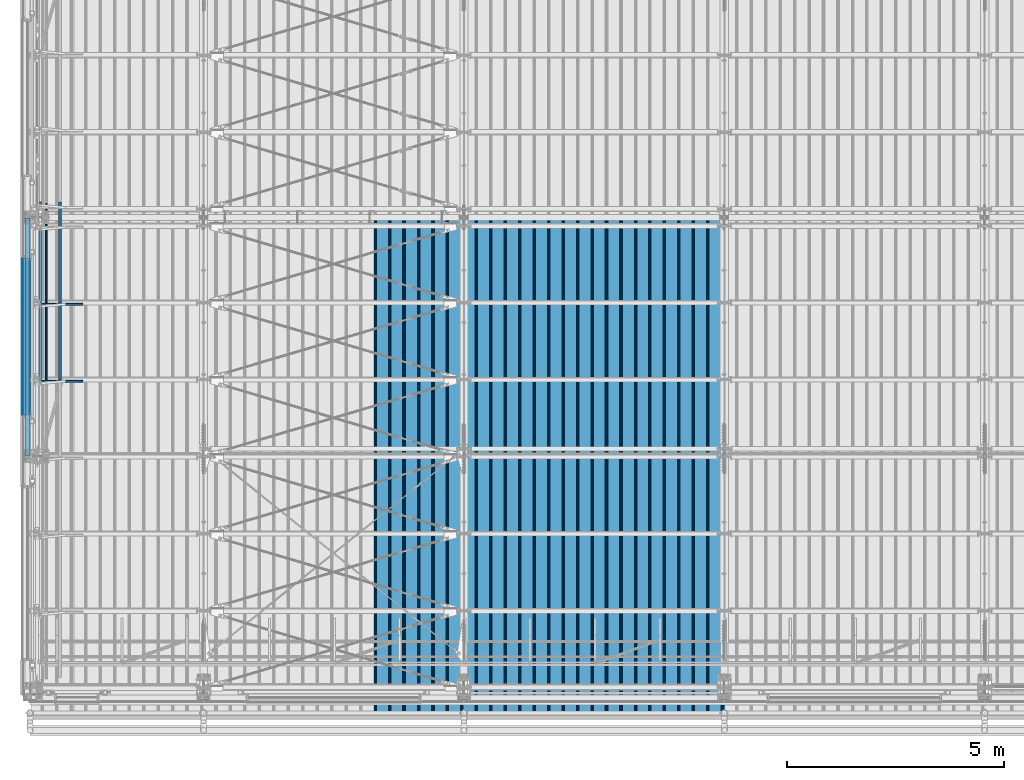
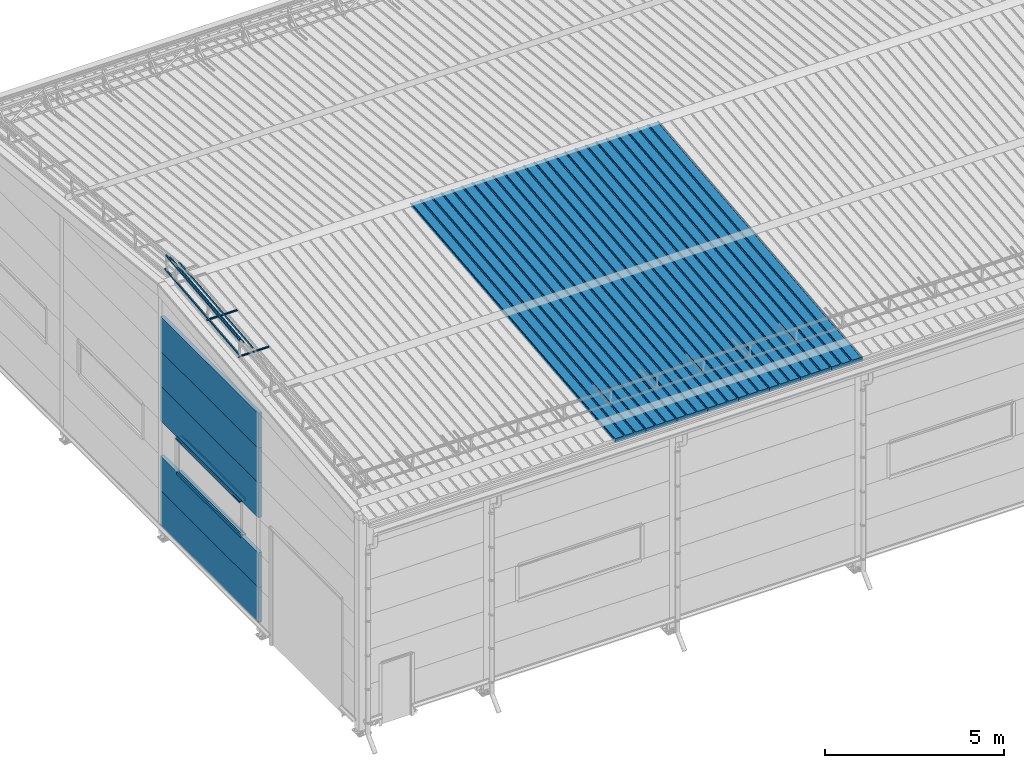
# One storey, part 38 of 709: 30 beams, 30 elements without a shape of their own.
"""IFC4 building model written with IfcOpenShell, lengths in millimetres."""

import ifcopenshell
import ifcopenshell.guid

model = None  # the IFC model being written
_history = None  # IfcOwnerHistory: only IFC2X3 demands one
_inside = {}  # id of a spatial element -> (the spatial element, [elements in it])
_under = {}  # id of a project, library or spatial element -> (it, [spatial elements below it])
_declared = {}  # id of a project -> (the project, [libraries it declares])
_typed = {}  # id of a type object -> (the type object, [elements of that type])
_made_of = {}  # id of a material, layer set ... -> (it, [elements and type objects made of it])


def new_model(schema):
    """Start an empty IFC model of exactly this schema.

    Asked for "IFC4X3", IfcOpenShell would pick the latest addendum, in which some entities
    have other attributes; the version numbers below select the first issue.
    IFC2X3 requires an IfcOwnerHistory on every rooted entity: one is made here for all.
    """
    global model, _history
    if schema == "IFC4X3":
        model = ifcopenshell.file(schema_version=(4, 3, 0, 0))
    else:
        model = ifcopenshell.file(schema=schema)
    _inside.clear()
    _under.clear()
    _declared.clear()
    _typed.clear()
    _made_of.clear()
    _history = None
    if model.schema == "IFC2X3":
        org = make("IfcOrganization", Name="unknown")
        user = make(
            "IfcPersonAndOrganization",
            ThePerson=make("IfcPerson", FamilyName="unknown"),
            TheOrganization=org,
        )
        app = make(
            "IfcApplication",
            ApplicationDeveloper=org,
            Version="unknown",
            ApplicationFullName="unknown",
            ApplicationIdentifier="unknown",
        )
        _history = make(
            "IfcOwnerHistory",
            OwningUser=user,
            OwningApplication=app,
            ChangeAction="ADDED",
            CreationDate=0,
        )
    return model


def make(cls, **values):
    """One entity of the class cls with the attributes given. An attribute that is None is left unset."""
    return model.create_entity(
        cls, **{name: value for name, value in values.items() if value is not None}
    )


def rooted(cls, **values):
    """An entity with a GlobalId (a new one), such as an element, a storey or a relation."""
    return make(cls, GlobalId=ifcopenshell.guid.new(), OwnerHistory=_history, **values)


def si_unit(unit_type, name, prefix=None):
    """IfcSIUnit, for example si_unit("LENGTHUNIT", "METRE", prefix="MILLI")."""
    return make("IfcSIUnit", UnitType=unit_type, Prefix=prefix, Name=name)


def assignment(units):
    """IfcUnitAssignment: the units of a project."""
    return None if units is None else make("IfcUnitAssignment", Units=units)


def point(xyz):
    """IfcCartesianPoint."""
    return None if xyz is None else make("IfcCartesianPoint", Coordinates=xyz)


def direction(xyz):
    """IfcDirection."""
    return None if xyz is None else make("IfcDirection", DirectionRatios=xyz)


def frame(location, z_axis=None, x_axis=None):
    """IfcAxis2Placement3D, a coordinate frame: its origin and axes. An axis left out is left unset."""
    return make(
        "IfcAxis2Placement3D",
        Location=point(location),
        Axis=direction(z_axis),
        RefDirection=direction(x_axis),
    )


def origin_with_axes():
    """The frame at (0, 0, 0) with the z axis (0, 0, 1) and the x axis (1, 0, 0) written out."""
    return frame((0.0, 0.0, 0.0), z_axis=(0.0, 0.0, 1.0), x_axis=(1.0, 0.0, 0.0))


def place(relative_to, where):
    """IfcLocalPlacement: puts the frame where relative to a parent placement (None: the world)."""
    return make(
        "IfcLocalPlacement", PlacementRelTo=relative_to, RelativePlacement=where
    )


def context(
    kind, dimensions, precision=None, world=None, true_north=None, identifier=None
):
    """IfcGeometricRepresentationContext, for example the 3D "Model" context."""
    return make(
        "IfcGeometricRepresentationContext",
        ContextIdentifier=identifier,
        ContextType=kind,
        CoordinateSpaceDimension=dimensions,
        Precision=precision,
        WorldCoordinateSystem=world,
        TrueNorth=true_north,
    )


def subcontext(parent, identifier, kind, view, scale=None):
    """IfcGeometricRepresentationSubContext, for example "Body" below "Model"."""
    return make(
        "IfcGeometricRepresentationSubContext",
        ContextIdentifier=identifier,
        ContextType=kind,
        ParentContext=parent,
        TargetScale=scale,
        TargetView=view,
    )


def project(units=None, contexts=None):
    """IfcProject with its units and contexts."""
    return rooted(
        "IfcProject",
        Name="project",
        RepresentationContexts=contexts,
        UnitsInContext=assignment(units),
    )


def spatial(cls, under=None, at=None, **own):
    """A site, building, storey or space (cls), placed at a placement, below another one or the project."""
    s = rooted(cls, ObjectPlacement=at, **own)
    if under is not None:
        _under.setdefault(under.id(), (under, []))[1].append(s)
    return s


def point_list(points):
    """IfcCartesianPointList2D or 3D."""
    cls = (
        "IfcCartesianPointList2D" if len(points[0]) == 2 else "IfcCartesianPointList3D"
    )
    return make(cls, CoordList=points)


def line(*indices):
    """IfcLineIndex: a straight run through numbered points of an indexed curve."""
    return model.create_entity("IfcLineIndex", indices)


def indexed_curve(points, segments=None, self_intersect=None):
    """IfcIndexedPolyCurve: lines and arcs through numbered points (the first is 1)."""
    return make(
        "IfcIndexedPolyCurve",
        Points=point_list(points),
        Segments=segments,
        SelfIntersect=self_intersect,
    )


def outline(outer, holes=None, kind="AREA"):
    """IfcArbitraryClosedProfileDef: a profile drawn as a closed curve; with holes, ...WithVoids."""
    if holes is None:
        return make("IfcArbitraryClosedProfileDef", ProfileType=kind, OuterCurve=outer)
    return make(
        "IfcArbitraryProfileDefWithVoids",
        ProfileType=kind,
        OuterCurve=outer,
        InnerCurves=holes,
    )


def extrude(swept, where, along, depth):
    """IfcExtrudedAreaSolid: the profile swept, set in the frame where, extruded along a direction by depth."""
    return make(
        "IfcExtrudedAreaSolid",
        SweptArea=swept,
        Position=where,
        ExtrudedDirection=direction(along),
        Depth=depth,
    )


def shape(context_of_items, identifier, shape_type, items):
    """IfcShapeRepresentation: the items that make up one representation, for example the "Body"."""
    return make(
        "IfcShapeRepresentation",
        ContextOfItems=context_of_items,
        RepresentationIdentifier=identifier,
        RepresentationType=shape_type,
        Items=items,
    )


def material(Name=None, Category=None):
    """IfcMaterial."""
    return make("IfcMaterial", Name=Name, Category=Category)


def made_of(thing, what):
    """Note that an element or type object is made of a material, layer set ...; save() writes the relation."""
    if what is not None:
        _made_of.setdefault(what.id(), (what, []))[1].append(thing)
    return thing


def element(
    cls,
    number,
    at=None,
    inside=None,
    cuts=None,
    type_object=None,
    material=None,
    context=None,
    identifier="Body",
    shape_type=None,
    held_by="IfcProductDefinitionShape",
    body=None,
    shapes=None,
    **own,
):
    """One element of the class cls, such as IfcWall. Its Tag is "e" and its number.

    at: its placement. inside: the storey or other place that contains it. cuts: it is an
    opening in that element (IfcRelVoidsElement). A single representation is given by context,
    identifier, shape_type and body (its items); several are given by shapes. held_by: the class
    of the entity that holds the representations. save() writes the other relations.
    """
    e = rooted(cls, Tag="e%d" % number, ObjectPlacement=at, **own)
    if body is not None:
        shapes = [shape(context, identifier, shape_type, body)]
    if shapes is not None:
        e.Representation = make(held_by, Representations=shapes)
    if inside is not None:
        _inside.setdefault(inside.id(), (inside, []))[1].append(e)
    if cuts is not None:
        rooted(
            "IfcRelVoidsElement", RelatingBuildingElement=cuts, RelatedOpeningElement=e
        )
    if type_object is not None:
        _typed.setdefault(type_object.id(), (type_object, []))[1].append(e)
    return made_of(e, material)


def aggregate(whole, parts):
    """IfcRelAggregates: a whole, such as a stair, and the parts it consists of."""
    return rooted("IfcRelAggregates", RelatingObject=whole, RelatedObjects=parts)


def save(model, path):
    """Write the relations noted so far, then the file.

    IfcRelAggregates (storeys below a building ...), IfcRelContainedInSpatialStructure (elements
    in a storey), IfcRelDefinesByType, IfcRelAssociatesMaterial and IfcRelDeclares: one each for
    every whole, place, type object, material and project.
    """
    for whole, parts in _under.values():
        aggregate(whole, parts)
    for where, things in _inside.values():
        rooted(
            "IfcRelContainedInSpatialStructure",
            RelatedElements=things,
            RelatingStructure=where,
        )
    for kind, things in _typed.values():
        rooted("IfcRelDefinesByType", RelatedObjects=things, RelatingType=kind)
    for what, things in _made_of.values():
        rooted("IfcRelAssociatesMaterial", RelatedObjects=things, RelatingMaterial=what)
    for by, libraries in _declared.values():
        rooted("IfcRelDeclares", RelatingContext=by, RelatedDefinitions=libraries)
    model.write(path)


model = new_model("IFC4")

# Units and contexts
model_context = context("Model", 3, precision=0.2, world=origin_with_axes(), true_north=direction((0.0, 1.0)))
body_context = subcontext(model_context, "Body", "Model", "MODEL_VIEW")
ifc_project = project(units=[si_unit("LENGTHUNIT", "METRE", prefix="MILLI"), si_unit("AREAUNIT", "SQUARE_METRE"), si_unit("VOLUMEUNIT", "CUBIC_METRE"), si_unit("MASSUNIT", "GRAM", prefix="KILO"), si_unit("TIMEUNIT", "SECOND"), si_unit("PLANEANGLEUNIT", "RADIAN"), si_unit("SOLIDANGLEUNIT", "STERADIAN"), si_unit("THERMODYNAMICTEMPERATUREUNIT", "DEGREE_CELSIUS"), si_unit("LUMINOUSINTENSITYUNIT", "LUMEN")], contexts=[model_context])

# Site, building, storey
site_placement = place(None, origin_with_axes())
site = spatial("IfcSite", under=ifc_project, at=site_placement, CompositionType="ELEMENT")
building_placement = place(site_placement, origin_with_axes())
building = spatial("IfcBuilding", under=site, at=building_placement, Name="Undefined", CompositionType="ELEMENT")
storey_placement = place(building_placement, origin_with_axes())
storey = spatial("IfcBuildingStorey", under=building, at=storey_placement, Name="Undefined", CompositionType="ELEMENT", Elevation=0.0)

# Assembly, beam
assembly_1_placement = place(storey_placement, frame((15452.44, -410.89541, 7279.78979), z_axis=(1.0, 0.0, 0.0), x_axis=(0.0, 0.9950371902, 0.099503719)))
assembly_1 = element("IfcElementAssembly", 1, at=assembly_1_placement, inside=storey)
ifc_material_1 = material(Name="Insulation", Category="Insulation")
beam_1_placement = place(assembly_1_placement, origin_with_axes())
beam_1 = element("IfcBeam", 2, at=beam_1_placement, material=ifc_material_1, ObjectType="P-99", context=body_context, shape_type="SolidModel", body=[
    extrude(outline(indexed_curve([(-509.8453, 89.5), (-490.1547, 89.5), (-471.67949, 57.5), (-471.67949, -88.5), (-436.67949, -88.5), (-436.67949, -91.5), (562.55841, -91.5), (562.55841, -89.5), (527.55841, -89.5), (527.55841, 57.5), (510.2379, 88.5), (489.7621, 88.5), (472.44159, 58.5), (196.71923, 58.5), (177.66667, 91.5), (155.66667, 91.5), (136.61411, 58.5), (-136.61411, 58.5), (-155.66667, 91.5), (-177.66667, 91.5), (-196.71923, 58.5), (-469.94744, 58.5), (-489.0, 91.5), (-511.0, 91.5), (-527.16581, 63.5), (-525.43376, 62.5)], segments=[line(1, 2, 3, 4, 5, 6, 7, 8, 9, 10, 11, 12, 13, 14, 15, 16, 17, 18, 19, 20, 21, 22, 23, 24, 25, 26, 1)])), frame((0.0, 0.0, 0.0), z_axis=(-1.0, 0.0, 0.0), x_axis=(0.0, 0.0, 1.0)), (0.0, 0.0, -1.0), 11459.0),
])
aggregate(assembly_1, [beam_1])

assembly_2_placement = place(storey_placement, frame((14452.44, -410.89541, 7279.78979), z_axis=(1.0, 0.0, 0.0), x_axis=(0.0, 0.9950371902, 0.099503719)))
assembly_2 = element("IfcElementAssembly", 3, at=assembly_2_placement, inside=storey)
beam_2_placement = place(assembly_2_placement, origin_with_axes())
beam_2 = element("IfcBeam", 4, at=beam_2_placement, material=ifc_material_1, ObjectType="P-99", context=body_context, shape_type="SolidModel", body=[
    extrude(outline(indexed_curve([(-509.8453, 89.5), (-490.1547, 89.5), (-471.67949, 57.5), (-471.67949, -88.5), (-436.67949, -88.5), (-436.67949, -91.5), (562.55841, -91.5), (562.55841, -89.5), (527.55841, -89.5), (527.55841, 57.5), (510.2379, 88.5), (489.7621, 88.5), (472.44159, 58.5), (196.71923, 58.5), (177.66667, 91.5), (155.66667, 91.5), (136.61411, 58.5), (-136.61411, 58.5), (-155.66667, 91.5), (-177.66667, 91.5), (-196.71923, 58.5), (-469.94744, 58.5), (-489.0, 91.5), (-511.0, 91.5), (-527.16581, 63.5), (-525.43376, 62.5)], segments=[line(1, 2, 3, 4, 5, 6, 7, 8, 9, 10, 11, 12, 13, 14, 15, 16, 17, 18, 19, 20, 21, 22, 23, 24, 25, 26, 1)])), frame((0.0, 0.0, 0.0), z_axis=(-1.0, 0.0, 0.0), x_axis=(0.0, 0.0, 1.0)), (0.0, 0.0, -1.0), 11459.0),
])
aggregate(assembly_2, [beam_2])

assembly_3_placement = place(storey_placement, frame((13452.44, -410.89541, 7279.78979), z_axis=(1.0, 0.0, 0.0), x_axis=(0.0, 0.9950371902, 0.099503719)))
assembly_3 = element("IfcElementAssembly", 5, at=assembly_3_placement, inside=storey)
beam_3_placement = place(assembly_3_placement, origin_with_axes())
beam_3 = element("IfcBeam", 6, at=beam_3_placement, material=ifc_material_1, ObjectType="P-99", context=body_context, shape_type="SolidModel", body=[
    extrude(outline(indexed_curve([(-509.8453, 89.5), (-490.1547, 89.5), (-471.67949, 57.5), (-471.67949, -88.5), (-436.67949, -88.5), (-436.67949, -91.5), (562.55841, -91.5), (562.55841, -89.5), (527.55841, -89.5), (527.55841, 57.5), (510.2379, 88.5), (489.7621, 88.5), (472.44159, 58.5), (196.71923, 58.5), (177.66667, 91.5), (155.66667, 91.5), (136.61411, 58.5), (-136.61411, 58.5), (-155.66667, 91.5), (-177.66667, 91.5), (-196.71923, 58.5), (-469.94744, 58.5), (-489.0, 91.5), (-511.0, 91.5), (-527.16581, 63.5), (-525.43376, 62.5)], segments=[line(1, 2, 3, 4, 5, 6, 7, 8, 9, 10, 11, 12, 13, 14, 15, 16, 17, 18, 19, 20, 21, 22, 23, 24, 25, 26, 1)])), frame((0.0, 0.0, 0.0), z_axis=(-1.0, 0.0, 0.0), x_axis=(0.0, 0.0, 1.0)), (0.0, 0.0, -1.0), 11459.0),
])
aggregate(assembly_3, [beam_3])

assembly_4_placement = place(storey_placement, frame((12452.44, -410.89541, 7279.78979), z_axis=(1.0, 0.0, 0.0), x_axis=(0.0, 0.9950371902, 0.099503719)))
assembly_4 = element("IfcElementAssembly", 7, at=assembly_4_placement, inside=storey)
beam_4_placement = place(assembly_4_placement, origin_with_axes())
beam_4 = element("IfcBeam", 8, at=beam_4_placement, material=ifc_material_1, ObjectType="P-99", context=body_context, shape_type="SolidModel", body=[
    extrude(outline(indexed_curve([(-509.8453, 89.5), (-490.1547, 89.5), (-471.67949, 57.5), (-471.67949, -88.5), (-436.67949, -88.5), (-436.67949, -91.5), (562.55841, -91.5), (562.55841, -89.5), (527.55841, -89.5), (527.55841, 57.5), (510.2379, 88.5), (489.7621, 88.5), (472.44159, 58.5), (196.71923, 58.5), (177.66667, 91.5), (155.66667, 91.5), (136.61411, 58.5), (-136.61411, 58.5), (-155.66667, 91.5), (-177.66667, 91.5), (-196.71923, 58.5), (-469.94744, 58.5), (-489.0, 91.5), (-511.0, 91.5), (-527.16581, 63.5), (-525.43376, 62.5)], segments=[line(1, 2, 3, 4, 5, 6, 7, 8, 9, 10, 11, 12, 13, 14, 15, 16, 17, 18, 19, 20, 21, 22, 23, 24, 25, 26, 1)])), frame((0.0, 0.0, 0.0), z_axis=(-1.0, 0.0, 0.0), x_axis=(0.0, 0.0, 1.0)), (0.0, 0.0, -1.0), 11459.0),
])
aggregate(assembly_4, [beam_4])

assembly_5_placement = place(storey_placement, frame((11452.44, -410.89541, 7279.78979), z_axis=(1.0, 0.0, 0.0), x_axis=(0.0, 0.9950371902, 0.099503719)))
assembly_5 = element("IfcElementAssembly", 9, at=assembly_5_placement, inside=storey)
beam_5_placement = place(assembly_5_placement, origin_with_axes())
beam_5 = element("IfcBeam", 10, at=beam_5_placement, material=ifc_material_1, ObjectType="P-99", context=body_context, shape_type="SolidModel", body=[
    extrude(outline(indexed_curve([(-509.8453, 89.5), (-490.1547, 89.5), (-471.67949, 57.5), (-471.67949, -88.5), (-436.67949, -88.5), (-436.67949, -91.5), (562.55841, -91.5), (562.55841, -89.5), (527.55841, -89.5), (527.55841, 57.5), (510.2379, 88.5), (489.7621, 88.5), (472.44159, 58.5), (196.71923, 58.5), (177.66667, 91.5), (155.66667, 91.5), (136.61411, 58.5), (-136.61411, 58.5), (-155.66667, 91.5), (-177.66667, 91.5), (-196.71923, 58.5), (-469.94744, 58.5), (-489.0, 91.5), (-511.0, 91.5), (-527.16581, 63.5), (-525.43376, 62.5)], segments=[line(1, 2, 3, 4, 5, 6, 7, 8, 9, 10, 11, 12, 13, 14, 15, 16, 17, 18, 19, 20, 21, 22, 23, 24, 25, 26, 1)])), frame((0.0, 0.0, 0.0), z_axis=(-1.0, 0.0, 0.0), x_axis=(0.0, 0.0, 1.0)), (0.0, 0.0, -1.0), 11459.0),
])
aggregate(assembly_5, [beam_5])

assembly_6_placement = place(storey_placement, frame((10452.44, -410.89541, 7279.78979), z_axis=(1.0, 0.0, 0.0), x_axis=(0.0, 0.9950371902, 0.099503719)))
assembly_6 = element("IfcElementAssembly", 11, at=assembly_6_placement, inside=storey)
beam_6_placement = place(assembly_6_placement, origin_with_axes())
beam_6 = element("IfcBeam", 12, at=beam_6_placement, material=ifc_material_1, ObjectType="P-99", context=body_context, shape_type="SolidModel", body=[
    extrude(outline(indexed_curve([(-509.8453, 89.5), (-490.1547, 89.5), (-471.67949, 57.5), (-471.67949, -88.5), (-436.67949, -88.5), (-436.67949, -91.5), (562.55841, -91.5), (562.55841, -89.5), (527.55841, -89.5), (527.55841, 57.5), (510.2379, 88.5), (489.7621, 88.5), (472.44159, 58.5), (196.71923, 58.5), (177.66667, 91.5), (155.66667, 91.5), (136.61411, 58.5), (-136.61411, 58.5), (-155.66667, 91.5), (-177.66667, 91.5), (-196.71923, 58.5), (-469.94744, 58.5), (-489.0, 91.5), (-511.0, 91.5), (-527.16581, 63.5), (-525.43376, 62.5)], segments=[line(1, 2, 3, 4, 5, 6, 7, 8, 9, 10, 11, 12, 13, 14, 15, 16, 17, 18, 19, 20, 21, 22, 23, 24, 25, 26, 1)])), frame((0.0, 0.0, 0.0), z_axis=(-1.0, 0.0, 0.0), x_axis=(0.0, 0.0, 1.0)), (0.0, 0.0, -1.0), 11459.0),
])
aggregate(assembly_6, [beam_6])

assembly_7_placement = place(storey_placement, frame((9452.44, -410.89541, 7279.78979), z_axis=(1.0, 0.0, 0.0), x_axis=(0.0, 0.9950371902, 0.099503719)))
assembly_7 = element("IfcElementAssembly", 13, at=assembly_7_placement, inside=storey)
beam_7_placement = place(assembly_7_placement, origin_with_axes())
beam_7 = element("IfcBeam", 14, at=beam_7_placement, material=ifc_material_1, ObjectType="P-99", context=body_context, shape_type="SolidModel", body=[
    extrude(outline(indexed_curve([(-509.8453, 89.5), (-490.1547, 89.5), (-471.67949, 57.5), (-471.67949, -88.5), (-436.67949, -88.5), (-436.67949, -91.5), (562.55841, -91.5), (562.55841, -89.5), (527.55841, -89.5), (527.55841, 57.5), (510.2379, 88.5), (489.7621, 88.5), (472.44159, 58.5), (196.71923, 58.5), (177.66667, 91.5), (155.66667, 91.5), (136.61411, 58.5), (-136.61411, 58.5), (-155.66667, 91.5), (-177.66667, 91.5), (-196.71923, 58.5), (-469.94744, 58.5), (-489.0, 91.5), (-511.0, 91.5), (-527.16581, 63.5), (-525.43376, 62.5)], segments=[line(1, 2, 3, 4, 5, 6, 7, 8, 9, 10, 11, 12, 13, 14, 15, 16, 17, 18, 19, 20, 21, 22, 23, 24, 25, 26, 1)])), frame((0.0, 0.0, 0.0), z_axis=(-1.0, 0.0, 0.0), x_axis=(0.0, 0.0, 1.0)), (0.0, 0.0, -1.0), 11459.0),
])
aggregate(assembly_7, [beam_7])

assembly_8_placement = place(storey_placement, frame((8452.44, -410.89541, 7279.78979), z_axis=(1.0, 0.0, 0.0), x_axis=(0.0, 0.9950371902, 0.099503719)))
assembly_8 = element("IfcElementAssembly", 15, at=assembly_8_placement, inside=storey)
beam_8_placement = place(assembly_8_placement, origin_with_axes())
beam_8 = element("IfcBeam", 16, at=beam_8_placement, material=ifc_material_1, ObjectType="P-99", context=body_context, shape_type="SolidModel", body=[
    extrude(outline(indexed_curve([(-509.8453, 89.5), (-490.1547, 89.5), (-471.67949, 57.5), (-471.67949, -88.5), (-436.67949, -88.5), (-436.67949, -91.5), (562.55841, -91.5), (562.55841, -89.5), (527.55841, -89.5), (527.55841, 57.5), (510.2379, 88.5), (489.7621, 88.5), (472.44159, 58.5), (196.71923, 58.5), (177.66667, 91.5), (155.66667, 91.5), (136.61411, 58.5), (-136.61411, 58.5), (-155.66667, 91.5), (-177.66667, 91.5), (-196.71923, 58.5), (-469.94744, 58.5), (-489.0, 91.5), (-511.0, 91.5), (-527.16581, 63.5), (-525.43376, 62.5)], segments=[line(1, 2, 3, 4, 5, 6, 7, 8, 9, 10, 11, 12, 13, 14, 15, 16, 17, 18, 19, 20, 21, 22, 23, 24, 25, 26, 1)])), frame((0.0, 0.0, 0.0), z_axis=(-1.0, 0.0, 0.0), x_axis=(0.0, 0.0, 1.0)), (0.0, 0.0, -1.0), 11459.0),
])
aggregate(assembly_8, [beam_8])

assembly_9_placement = place(storey_placement, frame((220.0, 7226.5335, 8222.92296), z_axis=(0.0, -0.099503719, 0.9950371902), x_axis=(1.0, 0.0, 0.0)))
assembly_9 = element("IfcElementAssembly", 17, at=assembly_9_placement, inside=storey)
ifc_material_2 = material(Name="Steel_Undefined", Category="STEEL")
beam_9_placement = place(assembly_9_placement, origin_with_axes())
beam_9 = element("IfcBeam", 18, at=beam_9_placement, material=ifc_material_2, ObjectType="601", context=body_context, shape_type="SolidModel", body=[
    extrude(outline(indexed_curve([(-20.0, -25.0), (20.0, -25.0), (20.0, -22.5), (-17.5, -22.5), (-17.5, 22.5), (20.0, 22.5), (20.0, 25.0), (-20.0, 25.0)], segments=[line(1, 2, 3, 4, 5, 6, 7, 8, 1)])), frame((0.0, 0.0, 0.0), z_axis=(-1.0, 0.0, 0.0), x_axis=(0.0, 0.0, 1.0)), (0.0, 0.0, -1.0), 1000.0),
])
aggregate(assembly_9, [beam_9])

assembly_10_placement = place(storey_placement, frame((220.0, 8999.83375, 8400.25299), z_axis=(0.0, -0.099503719, 0.9950371902), x_axis=(1.0, 0.0, 0.0)))
assembly_10 = element("IfcElementAssembly", 19, at=assembly_10_placement, inside=storey)
beam_10_placement = place(assembly_10_placement, origin_with_axes())
beam_10 = element("IfcBeam", 20, at=beam_10_placement, material=ifc_material_2, ObjectType="601", context=body_context, shape_type="SolidModel", body=[
    extrude(outline(indexed_curve([(-20.0, -25.0), (20.0, -25.0), (20.0, -22.5), (-17.5, -22.5), (-17.5, 22.5), (20.0, 22.5), (20.0, 25.0), (-20.0, 25.0)], segments=[line(1, 2, 3, 4, 5, 6, 7, 8, 1)])), frame((0.0, 0.0, 0.0), z_axis=(-1.0, 0.0, 0.0), x_axis=(0.0, 0.0, 1.0)), (0.0, 0.0, -1.0), 1000.0),
])
aggregate(assembly_10, [beam_10])

assembly_11_placement = place(storey_placement, frame((240.0, 7168.82134, 8800.04453), z_axis=(1.0, 0.0, 0.0), x_axis=(0.0, 0.9950371902, 0.099503719)))
assembly_11 = element("IfcElementAssembly", 21, at=assembly_11_placement, inside=storey)
beam_11_placement = place(assembly_11_placement, origin_with_axes())
beam_11 = element("IfcBeam", 22, at=beam_11_placement, material=ifc_material_2, ObjectType="610", context=body_context, shape_type="SolidModel", body=[
    extrude(outline(indexed_curve([(-20.0, -25.0), (20.0, -25.0), (20.0, -22.5), (-17.5, -22.5), (-17.5, 22.5), (20.0, 22.5), (20.0, 25.0), (-20.0, 25.0)], segments=[line(1, 2, 3, 4, 5, 6, 7, 8, 1)])), frame((0.0, 0.0, 0.0), z_axis=(-1.0, 0.0, 0.0), x_axis=(0.0, 0.0, 1.0)), (0.0, 0.0, -1.0), 1782.14469),
])
aggregate(assembly_11, [beam_11])

assembly_12_placement = place(storey_placement, frame((240.0, 7218.5732, 8302.52594), z_axis=(1.0, 0.0, 0.0), x_axis=(0.0, 0.9950371902, 0.099503719)))
assembly_12 = element("IfcElementAssembly", 23, at=assembly_12_placement, inside=storey)
beam_12_placement = place(assembly_12_placement, origin_with_axes())
beam_12 = element("IfcBeam", 24, at=beam_12_placement, material=ifc_material_2, ObjectType="610", context=body_context, shape_type="SolidModel", body=[
    extrude(outline(indexed_curve([(-20.0, -25.0), (20.0, -25.0), (20.0, -22.5), (-17.5, -22.5), (-17.5, 22.5), (20.0, 22.5), (20.0, 25.0), (-20.0, 25.0)], segments=[line(1, 2, 3, 4, 5, 6, 7, 8, 1)])), frame((0.0, 0.0, 0.0), z_axis=(-1.0, 0.0, 0.0), x_axis=(0.0, 0.0, 1.0)), (0.0, 0.0, -1.0), 1782.14469),
])
aggregate(assembly_12, [beam_12])

assembly_13_placement = place(storey_placement, frame((375.56349, 7181.4861, 8673.39698), z_axis=(0.7071067814, -0.0703597545, 0.7035975445), x_axis=(0.0, 0.9950371902, 0.099503719)))
assembly_13 = element("IfcElementAssembly", 25, at=assembly_13_placement, inside=storey)
beam_13_placement = place(assembly_13_placement, origin_with_axes())
beam_13 = element("IfcBeam", 26, at=beam_13_placement, material=ifc_material_2, ObjectType="610", context=body_context, shape_type="SolidModel", body=[
    extrude(outline(indexed_curve([(-20.0, -25.0), (20.0, -25.0), (20.0, -22.5), (-17.5, -22.5), (-17.5, 22.5), (20.0, 22.5), (20.0, 25.0), (-20.0, 25.0)], segments=[line(1, 2, 3, 4, 5, 6, 7, 8, 1)])), frame((0.0, 0.0, 0.0), z_axis=(-1.0, 0.0, 0.0), x_axis=(0.0, 0.0, 1.0)), (0.0, 0.0, -1.0), 1782.14469),
])
aggregate(assembly_13, [beam_13])

assembly_14_placement = place(storey_placement, frame((692.72078, 7213.04443, 8357.81368), z_axis=(0.7071067814, -0.0703597545, 0.7035975445), x_axis=(0.0, 0.9950371902, 0.099503719)))
assembly_14 = element("IfcElementAssembly", 27, at=assembly_14_placement, inside=storey)
beam_14_placement = place(assembly_14_placement, origin_with_axes())
beam_14 = element("IfcBeam", 28, at=beam_14_placement, material=ifc_material_2, ObjectType="610", context=body_context, shape_type="SolidModel", body=[
    extrude(outline(indexed_curve([(-20.0, -25.0), (20.0, -25.0), (20.0, -22.5), (-17.5, -22.5), (-17.5, 22.5), (20.0, 22.5), (20.0, 25.0), (-20.0, 25.0)], segments=[line(1, 2, 3, 4, 5, 6, 7, 8, 1)])), frame((0.0, 0.0, 0.0), z_axis=(-1.0, 0.0, 0.0), x_axis=(0.0, 0.0, 1.0)), (0.0, 0.0, -1.0), 1782.14469),
])
aggregate(assembly_14, [beam_14])

assembly_15_placement = place(storey_placement, frame((240.0, 8942.12159, 8977.37456), z_axis=(1.0, 0.0, 0.0), x_axis=(0.0, 0.9950371902, 0.099503719)))
assembly_15 = element("IfcElementAssembly", 29, at=assembly_15_placement, inside=storey)
beam_15_placement = place(assembly_15_placement, origin_with_axes())
beam_15 = element("IfcBeam", 30, at=beam_15_placement, material=ifc_material_2, ObjectType="611", context=body_context, shape_type="SolidModel", body=[
    extrude(outline(indexed_curve([(-20.0, -25.0), (20.0, -25.0), (20.0, -22.5), (-17.5, -22.5), (-17.5, 22.5), (20.0, 22.5), (20.0, 25.0), (-20.0, 25.0)], segments=[line(1, 2, 3, 4, 5, 6, 7, 8, 1)])), frame((0.0, 0.0, 0.0), z_axis=(-1.0, 0.0, 0.0), x_axis=(0.0, 0.0, 1.0)), (0.0, 0.0, -1.0), 2382.14469),
])
aggregate(assembly_15, [beam_15])

assembly_16_placement = place(storey_placement, frame((240.0, 8991.87345, 8479.85596), z_axis=(1.0, 0.0, 0.0), x_axis=(0.0, 0.9950371902, 0.099503719)))
assembly_16 = element("IfcElementAssembly", 31, at=assembly_16_placement, inside=storey)
beam_16_placement = place(assembly_16_placement, origin_with_axes())
beam_16 = element("IfcBeam", 32, at=beam_16_placement, material=ifc_material_2, ObjectType="611", context=body_context, shape_type="SolidModel", body=[
    extrude(outline(indexed_curve([(-20.0, -25.0), (20.0, -25.0), (20.0, -22.5), (-17.5, -22.5), (-17.5, 22.5), (20.0, 22.5), (20.0, 25.0), (-20.0, 25.0)], segments=[line(1, 2, 3, 4, 5, 6, 7, 8, 1)])), frame((0.0, 0.0, 0.0), z_axis=(-1.0, 0.0, 0.0), x_axis=(0.0, 0.0, 1.0)), (0.0, 0.0, -1.0), 2382.14469),
])
aggregate(assembly_16, [beam_16])

assembly_17_placement = place(storey_placement, frame((375.56349, 8954.78635, 8850.727), z_axis=(0.7071067814, -0.0703597545, 0.7035975445), x_axis=(0.0, 0.9950371902, 0.099503719)))
assembly_17 = element("IfcElementAssembly", 33, at=assembly_17_placement, inside=storey)
beam_17_placement = place(assembly_17_placement, origin_with_axes())
beam_17 = element("IfcBeam", 34, at=beam_17_placement, material=ifc_material_2, ObjectType="611", context=body_context, shape_type="SolidModel", body=[
    extrude(outline(indexed_curve([(-20.0, -25.0), (20.0, -25.0), (20.0, -22.5), (-17.5, -22.5), (-17.5, 22.5), (20.0, 22.5), (20.0, 25.0), (-20.0, 25.0)], segments=[line(1, 2, 3, 4, 5, 6, 7, 8, 1)])), frame((0.0, 0.0, 0.0), z_axis=(-1.0, 0.0, 0.0), x_axis=(0.0, 0.0, 1.0)), (0.0, 0.0, -1.0), 2382.14469),
])
aggregate(assembly_17, [beam_17])

assembly_18_placement = place(storey_placement, frame((692.72078, 8986.34468, 8535.1437), z_axis=(0.7071067814, -0.0703597545, 0.7035975445), x_axis=(0.0, 0.9950371902, 0.099503719)))
assembly_18 = element("IfcElementAssembly", 35, at=assembly_18_placement, inside=storey)
beam_18_placement = place(assembly_18_placement, origin_with_axes())
beam_18 = element("IfcBeam", 36, at=beam_18_placement, material=ifc_material_2, ObjectType="611", context=body_context, shape_type="SolidModel", body=[
    extrude(outline(indexed_curve([(-20.0, -25.0), (20.0, -25.0), (20.0, -22.5), (-17.5, -22.5), (-17.5, 22.5), (20.0, 22.5), (20.0, 25.0), (-20.0, 25.0)], segments=[line(1, 2, 3, 4, 5, 6, 7, 8, 1)])), frame((0.0, 0.0, 0.0), z_axis=(-1.0, 0.0, 0.0), x_axis=(0.0, 0.0, 1.0)), (0.0, 0.0, -1.0), 2382.14469),
])
aggregate(assembly_18, [beam_18])

assembly_19_placement = place(storey_placement, frame((-60.0, 5510.0, 895.0), z_axis=(0.0, 0.0, -1.0), x_axis=(0.0, 1.0, 0.0)))
assembly_19 = element("IfcElementAssembly", 37, at=assembly_19_placement, inside=storey)
beam_19_placement = place(assembly_19_placement, origin_with_axes())
beam_19 = element("IfcBeam", 38, at=beam_19_placement, material=ifc_material_1, ObjectType="P-135", context=body_context, shape_type="SolidModel", body=[
    extrude(outline(indexed_curve([(-595.0, -60.0), (595.0, -60.0), (595.0, 60.0), (-595.0, 60.0)], segments=[line(1, 2, 3, 4, 1)])), frame((0.0, 0.0, 0.0), z_axis=(-1.0, 0.0, 0.0), x_axis=(0.0, 0.0, 1.0)), (0.0, 0.0, -1.0), 5480.0),
])
aggregate(assembly_19, [beam_19])

assembly_20_placement = place(storey_placement, frame((-60.0, 5510.0, 2085.0), z_axis=(0.0, 0.0, -1.0), x_axis=(0.0, 1.0, 0.0)))
assembly_20 = element("IfcElementAssembly", 39, at=assembly_20_placement, inside=storey)
beam_20_placement = place(assembly_20_placement, origin_with_axes())
beam_20 = element("IfcBeam", 40, at=beam_20_placement, material=ifc_material_1, ObjectType="P-135", context=body_context, shape_type="SolidModel", body=[
    extrude(outline(indexed_curve([(-595.0, -60.0), (595.0, -60.0), (595.0, 60.0), (-595.0, 60.0)], segments=[line(1, 2, 3, 4, 1)])), frame((0.0, 0.0, 0.0), z_axis=(-1.0, 0.0, 0.0), x_axis=(0.0, 0.0, 1.0)), (0.0, 0.0, -1.0), 5480.0),
])
aggregate(assembly_20, [beam_20])

assembly_21_placement = place(storey_placement, frame((-60.0, 5510.0, 4465.0), z_axis=(0.0, 0.0, -1.0), x_axis=(0.0, 1.0, 0.0)))
assembly_21 = element("IfcElementAssembly", 41, at=assembly_21_placement, inside=storey)
beam_21_placement = place(assembly_21_placement, origin_with_axes())
beam_21 = element("IfcBeam", 42, at=beam_21_placement, material=ifc_material_1, ObjectType="P-135", context=body_context, shape_type="SolidModel", body=[
    extrude(outline(indexed_curve([(-595.0, -60.0), (595.0, -60.0), (595.0, 60.0), (-595.0, 60.0)], segments=[line(1, 2, 3, 4, 1)])), frame((0.0, 0.0, 0.0), z_axis=(-1.0, 0.0, 0.0), x_axis=(0.0, 0.0, 1.0)), (0.0, 0.0, -1.0), 5480.0),
])
aggregate(assembly_21, [beam_21])

assembly_22_placement = place(storey_placement, frame((-60.0, 5510.0, 5655.0), z_axis=(0.0, 0.0, -1.0), x_axis=(0.0, 1.0, 0.0)))
assembly_22 = element("IfcElementAssembly", 43, at=assembly_22_placement, inside=storey)
beam_22_placement = place(assembly_22_placement, origin_with_axes())
beam_22 = element("IfcBeam", 44, at=beam_22_placement, material=ifc_material_1, ObjectType="P-135", context=body_context, shape_type="SolidModel", body=[
    extrude(outline(indexed_curve([(-595.0, -60.0), (595.0, -60.0), (595.0, 60.0), (-595.0, 60.0)], segments=[line(1, 2, 3, 4, 1)])), frame((0.0, 0.0, 0.0), z_axis=(-1.0, 0.0, 0.0), x_axis=(0.0, 0.0, 1.0)), (0.0, 0.0, -1.0), 5480.0),
])
aggregate(assembly_22, [beam_22])

assembly_23_placement = place(storey_placement, frame((-60.0, 5510.0, 6845.0), z_axis=(0.0, 0.0, -1.0), x_axis=(0.0, 1.0, 0.0)))
assembly_23 = element("IfcElementAssembly", 45, at=assembly_23_placement, inside=storey)
beam_23_placement = place(assembly_23_placement, origin_with_axes())
beam_23 = element("IfcBeam", 46, at=beam_23_placement, material=ifc_material_1, ObjectType="P-135", context=body_context, shape_type="SolidModel", body=[
    extrude(outline(indexed_curve([(-595.0, -60.0), (595.0, -60.0), (595.0, 60.0), (-595.0, 60.0)], segments=[line(1, 2, 3, 4, 1)])), frame((0.0, 0.0, 0.0), z_axis=(-1.0, 0.0, 0.0), x_axis=(0.0, 0.0, 1.0)), (0.0, 0.0, -1.0), 5480.0),
])
aggregate(assembly_23, [beam_23])

assembly_24_placement = place(storey_placement, frame((-1.0, 10050.0, 2725.0), z_axis=(1.0, 0.0, 0.0), x_axis=(0.0, -1.0, 0.0)))
assembly_24 = element("IfcElementAssembly", 47, at=assembly_24_placement, inside=storey)
beam_24_placement = place(assembly_24_placement, origin_with_axes())
beam_24 = element("IfcBeam", 48, at=beam_24_placement, material=ifc_material_2, context=body_context, shape_type="SolidModel", body=[
    extrude(outline(indexed_curve([(-25.0, -1.0), (25.0, -1.0), (25.0, 99.0), (23.0, 99.0), (23.0, 1.0), (-25.0, 1.0)], segments=[line(1, 2, 3, 4, 5, 6, 1)])), frame((0.0, 0.0, 0.0), z_axis=(-1.0, 0.0, 0.0), x_axis=(0.0, 0.0, 1.0)), (0.0, 0.0, -1.0), 3600.0),
])
aggregate(assembly_24, [beam_24])

assembly_25_placement = place(storey_placement, frame((-60.0, 6450.0, 2680.0), z_axis=(1.0, 0.0, 0.0), x_axis=(0.0, 1.0, 0.0)))
assembly_25 = element("IfcElementAssembly", 49, at=assembly_25_placement, inside=storey)
beam_25_placement = place(assembly_25_placement, origin_with_axes())
beam_25 = element("IfcBeam", 50, at=beam_25_placement, material=ifc_material_2, context=body_context, shape_type="SolidModel", body=[
    extrude(outline(indexed_curve([(-70.0, -25.0), (-68.0, -25.0), (-68.0, 23.0), (68.0, 23.0), (68.0, -25.0), (70.0, -25.0), (70.0, 25.0), (-70.0, 25.0)], segments=[line(1, 2, 3, 4, 5, 6, 7, 8, 1)])), frame((0.0, 0.0, 0.0), z_axis=(-1.0, 0.0, 0.0), x_axis=(0.0, 0.0, 1.0)), (0.0, 0.0, -1.0), 3600.0),
])
aggregate(assembly_25, [beam_25])

assembly_26_placement = place(storey_placement, frame((-121.0, 6450.0, 2725.0), z_axis=(-1.0, 0.0, 0.0), x_axis=(0.0, 1.0, 0.0)))
assembly_26 = element("IfcElementAssembly", 51, at=assembly_26_placement, inside=storey)
beam_26_placement = place(assembly_26_placement, origin_with_axes())
beam_26 = element("IfcBeam", 52, at=beam_26_placement, material=ifc_material_2, context=body_context, shape_type="SolidModel", body=[
    extrude(outline(indexed_curve([(-25.0, -1.0), (25.0, -1.0), (25.0, 99.0), (23.0, 99.0), (23.0, 1.0), (-25.0, 1.0)], segments=[line(1, 2, 3, 4, 5, 6, 1)])), frame((0.0, 0.0, 0.0), z_axis=(-1.0, 0.0, 0.0), x_axis=(0.0, 0.0, 1.0)), (0.0, 0.0, -1.0), 3600.0),
])
aggregate(assembly_26, [beam_26])

assembly_27_placement = place(storey_placement, frame((-1.0, 6450.0, 3845.0), z_axis=(1.0, 0.0, 0.0), x_axis=(0.0, 1.0, 0.0)))
assembly_27 = element("IfcElementAssembly", 53, at=assembly_27_placement, inside=storey)
beam_27_placement = place(assembly_27_placement, origin_with_axes())
beam_27 = element("IfcBeam", 54, at=beam_27_placement, material=ifc_material_2, context=body_context, shape_type="SolidModel", body=[
    extrude(outline(indexed_curve([(-25.0, -1.0), (25.0, -1.0), (25.0, 99.0), (23.0, 99.0), (23.0, 1.0), (-25.0, 1.0)], segments=[line(1, 2, 3, 4, 5, 6, 1)])), frame((0.0, 0.0, 0.0), z_axis=(-1.0, 0.0, 0.0), x_axis=(0.0, 0.0, 1.0)), (0.0, 0.0, -1.0), 3600.0),
])
aggregate(assembly_27, [beam_27])

assembly_28_placement = place(storey_placement, frame((-60.0, 10050.0, 3890.0), z_axis=(1.0, 0.0, 0.0), x_axis=(0.0, -1.0, 0.0)))
assembly_28 = element("IfcElementAssembly", 55, at=assembly_28_placement, inside=storey)
beam_28_placement = place(assembly_28_placement, origin_with_axes())
beam_28 = element("IfcBeam", 56, at=beam_28_placement, material=ifc_material_2, context=body_context, shape_type="SolidModel", body=[
    extrude(outline(indexed_curve([(-70.0, -25.0), (-68.0, -25.0), (-68.0, 23.0), (68.0, 23.0), (68.0, -25.0), (70.0, -25.0), (70.0, 25.0), (-70.0, 25.0)], segments=[line(1, 2, 3, 4, 5, 6, 7, 8, 1)])), frame((0.0, 0.0, 0.0), z_axis=(-1.0, 0.0, 0.0), x_axis=(0.0, 0.0, 1.0)), (0.0, 0.0, -1.0), 3600.0),
])
aggregate(assembly_28, [beam_28])

assembly_29_placement = place(storey_placement, frame((-121.0, 10050.0, 3845.0), z_axis=(-1.0, 0.0, 0.0), x_axis=(0.0, -1.0, 0.0)))
assembly_29 = element("IfcElementAssembly", 57, at=assembly_29_placement, inside=storey)
beam_29_placement = place(assembly_29_placement, origin_with_axes())
beam_29 = element("IfcBeam", 58, at=beam_29_placement, material=ifc_material_2, context=body_context, shape_type="SolidModel", body=[
    extrude(outline(indexed_curve([(-25.0, -1.0), (25.0, -1.0), (25.0, 99.0), (23.0, 99.0), (23.0, 1.0), (-25.0, 1.0)], segments=[line(1, 2, 3, 4, 5, 6, 1)])), frame((0.0, 0.0, 0.0), z_axis=(-1.0, 0.0, 0.0), x_axis=(0.0, 0.0, 1.0)), (0.0, 0.0, -1.0), 3600.0),
])
aggregate(assembly_29, [beam_29])

assembly_30_placement = place(storey_placement, frame((-171.0, 10050.0, 3830.0), z_axis=(-1.0, 0.0, 0.0), x_axis=(0.0, -1.0, 0.0)))
assembly_30 = element("IfcElementAssembly", 59, at=assembly_30_placement, inside=storey)
beam_30_placement = place(assembly_30_placement, origin_with_axes())
beam_30 = element("IfcBeam", 60, at=beam_30_placement, material=ifc_material_2, context=body_context, shape_type="SolidModel", body=[
    extrude(outline(indexed_curve([(-10.0, -1.0), (10.0, -1.0), (10.0, 49.0), (8.0, 49.0), (8.0, 1.0), (-10.0, 1.0)], segments=[line(1, 2, 3, 4, 5, 6, 1)])), frame((0.0, 0.0, 0.0), z_axis=(-1.0, 0.0, 0.0), x_axis=(0.0, 0.0, 1.0)), (0.0, 0.0, -1.0), 3600.0),
])
aggregate(assembly_30, [beam_30])

save(model, "model.ifc")
